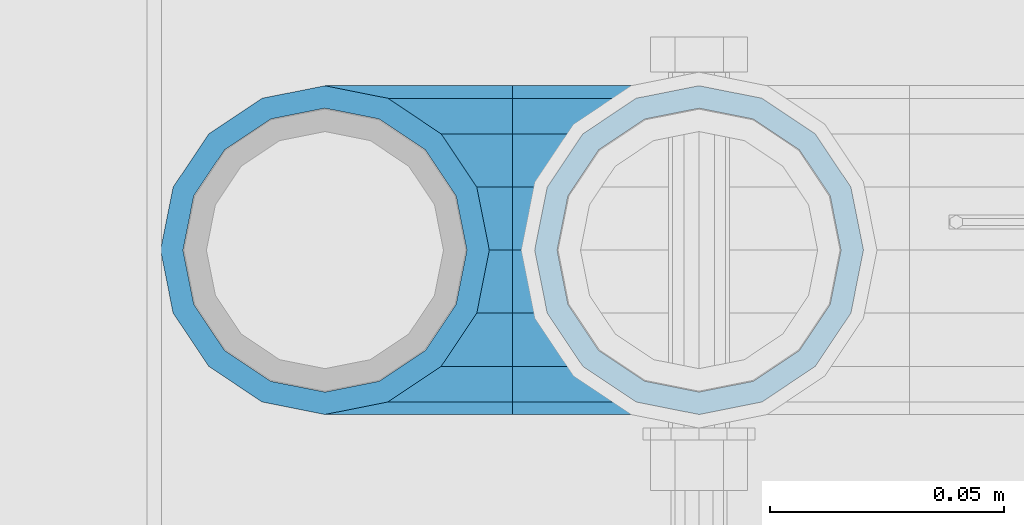
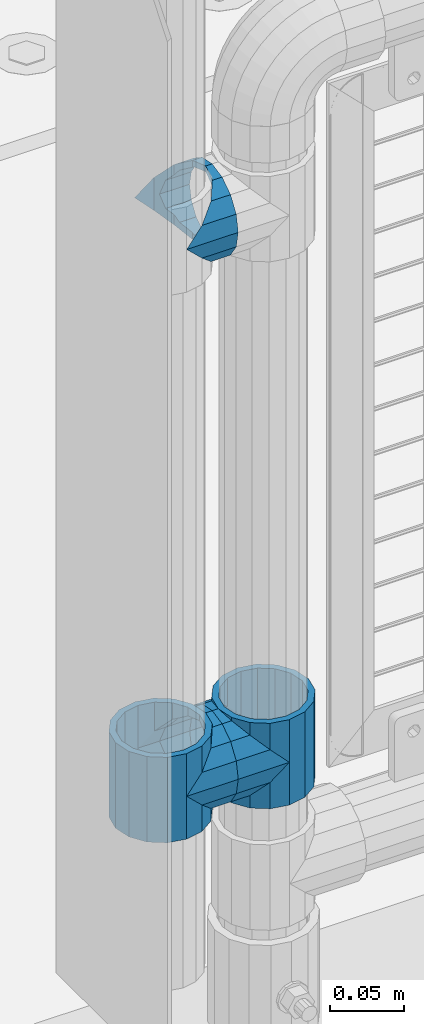
# One storey, part 144 of 247: 5 beams.
"""IFC2X3 building model written with IfcOpenShell, lengths in millimetres."""

from ifc_helpers import new_model, si_unit, frame, origin_with_axes, place, context, subcontext, project, spatial, faceted_brep, material, type_object, element, save


model = new_model("IFC2X3")

# Units and contexts
model_context = context("Model", 3, precision=1e-05, world=origin_with_axes())
body_context = subcontext(model_context, "Body", "Model", "MODEL_VIEW")
ifc_project = project(units=[si_unit("LENGTHUNIT", "METRE", prefix="MILLI"), si_unit("AREAUNIT", "SQUARE_METRE"), si_unit("VOLUMEUNIT", "CUBIC_METRE"), si_unit("MASSUNIT", "GRAM", prefix="KILO"), si_unit("TIMEUNIT", "SECOND"), si_unit("PLANEANGLEUNIT", "RADIAN"), si_unit("SOLIDANGLEUNIT", "STERADIAN"), si_unit("THERMODYNAMICTEMPERATUREUNIT", "DEGREE_CELSIUS"), si_unit("LUMINOUSINTENSITYUNIT", "LUMEN")], contexts=[model_context])

# Site, building, storey
site_placement = place(None, origin_with_axes())
site = spatial("IfcSite", under=ifc_project, at=site_placement, CompositionType="ELEMENT")
building_placement = place(site_placement, origin_with_axes())
building = spatial("IfcBuilding", under=site, at=building_placement, Name="Standard", CompositionType="ELEMENT")
storey_placement = place(building_placement, origin_with_axes())
storey = spatial("IfcBuildingStorey", under=building, at=storey_placement, Name="Undefined", CompositionType="ELEMENT", Elevation=0.0)

# Beams
ifc_material = material(Name="Misc_Undefined")
beam_type = type_object("IfcBeamType", PredefinedType="NOTDEFINED")
beam_1_placement = place(storey_placement, frame((541.0, 7664.5, 398.669999999999), z_axis=(0.0, -0.999999999999548, -9.5100000000016e-07), x_axis=(1.0, 0.0, 0.0)))
element("IfcBeam", 1, at=beam_1_placement, inside=storey, type_object=beam_type, material=ifc_material, context=body_context, shape_type="Brep", body=[
    faceted_brep([(0.0, 0.0, -35.1499999999996), (13.4513226476338, -13.4513226476329, -32.4743655677721), (13.4513226476338, 13.4513226476329, -32.4743655677721), (32.4743655677721, 32.4743655677717, 13.4513226476329), (32.4743655677721, 26.8123795176755, 13.4513226476329), (27.1226768591096, 21.4606908090117, 21.4606908090118), (24.8548033587067, 16.3810424080046, 24.8548033587067), (24.8548033587067, 24.8548033587072, 24.8548033587067), (0.0, 0.0, 35.1499999999996), (13.4513226476338, 13.4513226476329, 32.4743655677721), (13.4513226476338, -13.4513226476329, 32.4743655677721), (20.0882031229812, 11.6144421722805, 28.0397438117179), (16.6306603983649, 0.0, 30.3500000000004), (20.0882031229812, -11.6144421722805, 28.0397438117179), (24.8548033587067, -16.3810424080045, 24.8548033587067), (24.8548033587067, -24.8548033587072, 24.8548033587067), (27.1226768591096, -21.4606908090117, 21.4606908090118), (32.4743655677721, -26.8123795176755, 13.4513226476329), (32.4743655677721, -32.4743655677717, 13.4513226476329), (32.8397438117172, -28.0397438117175, 11.6144421722802), (35.1499999999996, -30.35, 0.0), (35.1499999999996, -35.15, 0.0), (32.4743655677721, -26.8123795176766, -13.4513226476329), (32.4743655677721, -32.4743655677717, -13.4513226476329), (32.8397438117172, -28.0397438117175, -11.6144421722802), (24.8548033587067, -16.3810424080045, -24.8548033587067), (24.8548033587067, -24.8548033587072, -24.8548033587067), (27.1226768591059, -21.4606908090117, -21.4606908090118), (20.0882031229885, -11.6144421722805, -28.0397438117179), (16.6306603983739, 0.0, -30.3500000000004), (20.0882031229885, 11.6144421722805, -28.0397438117179), (24.8548033587067, 16.3810424080029, -24.8548033587067), (24.8548033587067, 24.8548033587072, -24.8548033587067), (27.1226768591059, 21.4606908090117, -21.4606908090118), (32.4743655677721, 26.8123795176755, -13.4513226476329), (32.4743655677721, 32.4743655677717, -13.4513226476329), (32.8397438117172, 28.0397438117175, -11.6144421722802), (35.1499999999996, 30.35, 0.0), (35.1499999999996, 35.15, 0.0), (32.8397438117172, 28.0397438117175, 11.6144421722802), (40.1500000000015, -35.15, 0.0), (40.1500000000015, -32.4743655677717, 13.4513226476329), (40.1500000000015, -24.8548033587072, 24.8548033587067), (40.1500000000015, -13.4513226476329, 32.4743655677721), (40.1500000000015, 0.0, 35.1499999999996), (40.1500000000015, 13.4513226476329, 32.4743655677721), (40.1500000000015, 24.8548033587072, 24.8548033587067), (40.1500000000015, 32.4743655677717, 13.4513226476329), (40.1500000000015, 35.15, 0.0), (40.1500000000015, -24.8548033587072, -24.8548033587067), (40.1500000000015, -32.4743655677717, -13.4513226476329), (40.1500000000015, -13.4513226476329, -32.4743655677721), (40.1500000000015, 0.0, -35.1499999999996), (40.1500000000015, 13.4513226476329, -32.4743655677721), (40.1500000000015, 24.8548033587072, -24.8548033587067), (40.1500000000015, 32.4743655677717, -13.4513226476329), (40.1500000000015, -21.4606908090117, 21.4606908090118), (40.1500000000015, -11.6144421722805, 28.0397438117179), (40.1500000000015, 0.0, 30.3500000000004), (40.1500000000015, 11.6144421722805, 28.0397438117179), (40.1500000000015, 21.4606908090117, 21.4606908090118), (40.1500000000015, 28.0397438117175, 11.6144421722802), (40.1500000000015, 30.35, 0.0), (40.1500000000015, 28.0397438117175, -11.6144421722802), (40.1500000000015, 21.4606908090117, -21.4606908090118), (40.1500000000015, 11.6144421722805, -28.0397438117179), (40.1500000000015, 0.0, -30.3500000000004), (40.1500000000015, -11.6144421722805, -28.0397438117179), (40.1500000000015, -21.4606908090117, -21.4606908090118), (40.1500000000015, -28.0397438117175, -11.6144421722802), (40.1500000000015, -30.35, 0.0), (40.1500000000015, -28.0397438117175, 11.6144421722802)], [[[0, 1, 2]], [[3, 4, 5, 6, 7]], [[8, 9, 10]], [[7, 6, 11, 12, 13, 14, 15, 10, 9]], [[16, 17, 18, 15, 14]], [[19, 20, 21, 18, 17]], [[22, 23, 21, 20, 24]], [[25, 26, 23, 22, 27]], [[2, 1, 26, 25, 28, 29, 30, 31, 32]], [[32, 31, 33, 34, 35]], [[35, 34, 36, 37, 38]], [[38, 37, 39, 4, 3]], [[40, 41, 18, 21]], [[41, 42, 15, 18]], [[42, 43, 10, 15]], [[43, 44, 8, 10]], [[44, 45, 9, 8]], [[45, 46, 7, 9]], [[46, 47, 3, 7]], [[47, 48, 38, 3]], [[49, 50, 23, 26]], [[51, 49, 26, 1]], [[52, 51, 1, 0]], [[53, 52, 0, 2]], [[54, 53, 2, 32]], [[55, 54, 32, 35]], [[48, 55, 35, 38]], [[50, 40, 21, 23]], [[49, 51, 52, 53, 54, 55, 48, 47, 46, 45, 44, 43, 42, 41, 40, 50], [56, 57, 58, 59, 60, 61, 62, 63, 64, 65, 66, 67, 68, 69, 70, 71]], [[63, 62, 37, 36]], [[33, 64, 63, 36, 34]], [[30, 65, 64, 33, 31]], [[66, 65, 30, 29]], [[67, 66, 29, 28]], [[68, 67, 28, 25, 27]], [[69, 68, 27, 22, 24]], [[70, 69, 24, 20]], [[71, 70, 20, 19]], [[16, 56, 71, 19, 17]], [[13, 57, 56, 16, 14]], [[58, 57, 13, 12]], [[59, 58, 12, 11]], [[60, 59, 11, 6, 5]], [[61, 60, 5, 4, 39]], [[62, 61, 39, 37]]]),
])
beam_2_placement = place(storey_placement, frame((621.0, 7664.5, 398.669999999999), z_axis=(0.0, 1.0, 0.0), x_axis=(-1.0, 0.0, 0.0)))
element("IfcBeam", 2, at=beam_2_placement, inside=storey, type_object=beam_type, material=ifc_material, context=body_context, shape_type="Brep", body=[
    faceted_brep([(0.0, 0.0, -35.1499999999996), (13.4513226476338, -13.4513226476329, -32.4743655677721), (13.4513226476338, 13.4513226476329, -32.4743655677721), (27.1226768591096, -21.4606908090117, 21.4606908090118), (32.4743655677721, -26.8123795176755, 13.4513226476329), (32.4743655677721, -32.4743655677717, 13.4513226476329), (24.8548033587067, -24.8548033587072, 24.8548033587067), (24.8548033587067, -16.3810424080045, 24.8548033587067), (32.8397438117172, -28.0397438117175, 11.6144421722802), (35.1499999999996, -30.35, 0.0), (35.1499999999996, -35.15, 0.0), (32.4743655677721, -26.8123795176766, -13.4513226476329), (32.4743655677721, -32.4743655677717, -13.4513226476329), (32.8397438117172, -28.0397438117175, -11.6144421722802), (24.8548033587067, -16.3810424080045, -24.8548033587067), (24.8548033587067, -24.8548033587072, -24.8548033587067), (27.1226768591059, -21.4606908090117, -21.4606908090118), (20.0882031229885, -11.6144421722805, -28.0397438117179), (16.6306603983739, 0.0, -30.3500000000004), (20.0882031229885, 11.6144421722805, -28.0397438117179), (24.8548033587067, 16.3810424080029, -24.8548033587067), (24.8548033587067, 24.8548033587072, -24.8548033587067), (27.1226768591059, 21.4606908090117, -21.4606908090118), (32.4743655677721, 26.8123795176755, -13.4513226476329), (32.4743655677721, 32.4743655677717, -13.4513226476329), (32.8397438117172, 28.0397438117175, -11.6144421722802), (35.1499999999996, 30.35, 0.0), (35.1499999999996, 35.15, 0.0), (32.8397438117172, 28.0397438117175, 11.6144421722802), (32.4743655677721, 26.8123795176755, 13.4513226476329), (32.4743655677721, 32.4743655677717, 13.4513226476329), (27.1226768591096, 21.4606908090117, 21.4606908090118), (24.8548033587067, 16.3810424080046, 24.8548033587067), (24.8548033587067, 24.8548033587072, 24.8548033587067), (0.0, 0.0, 35.1499999999996), (13.4513226476338, 13.4513226476329, 32.4743655677721), (13.4513226476338, -13.4513226476329, 32.4743655677721), (20.0882031229812, 11.6144421722805, 28.0397438117179), (16.6306603983649, 0.0, 30.3500000000004), (20.0882031229812, -11.6144421722805, 28.0397438117179), (40.1500000000015, -35.15, 0.0), (40.1500000000015, -32.4743655677717, 13.4513226476329), (40.1500000000015, -24.8548033587072, 24.8548033587067), (40.1500000000015, -13.4513226476329, 32.4743655677721), (40.1500000000015, 0.0, 35.1499999999996), (40.1500000000015, -24.8548033587072, -24.8548033587067), (40.1500000000015, -32.4743655677717, -13.4513226476329), (40.1500000000015, -13.4513226476329, -32.4743655677721), (40.1500000000015, 0.0, -35.1499999999996), (40.1500000000015, 13.4513226476329, -32.4743655677721), (40.1500000000015, 24.8548033587072, -24.8548033587067), (40.1500000000015, 32.4743655677717, -13.4513226476329), (40.1500000000015, 35.15, 0.0), (40.1500000000015, 32.4743655677717, 13.4513226476329), (40.1500000000015, 24.8548033587072, 24.8548033587067), (40.1500000000015, 13.4513226476329, 32.4743655677721), (40.1500000000015, -21.4606908090117, 21.4606908090118), (40.1500000000015, -11.6144421722805, 28.0397438117179), (40.1500000000015, 0.0, 30.3500000000004), (40.1500000000015, 11.6144421722805, 28.0397438117179), (40.1500000000015, 21.4606908090117, 21.4606908090118), (40.1500000000015, 28.0397438117175, 11.6144421722802), (40.1500000000015, 30.35, 0.0), (40.1500000000015, 28.0397438117175, -11.6144421722802), (40.1500000000015, 21.4606908090117, -21.4606908090118), (40.1500000000015, 11.6144421722805, -28.0397438117179), (40.1500000000015, 0.0, -30.3500000000004), (40.1500000000015, -11.6144421722805, -28.0397438117179), (40.1500000000015, -21.4606908090117, -21.4606908090118), (40.1500000000015, -28.0397438117175, -11.6144421722802), (40.1500000000015, -30.35, 0.0), (40.1500000000015, -28.0397438117175, 11.6144421722802)], [[[0, 1, 2]], [[3, 4, 5, 6, 7]], [[8, 9, 10, 5, 4]], [[11, 12, 10, 9, 13]], [[14, 15, 12, 11, 16]], [[2, 1, 15, 14, 17, 18, 19, 20, 21]], [[21, 20, 22, 23, 24]], [[24, 23, 25, 26, 27]], [[27, 26, 28, 29, 30]], [[30, 29, 31, 32, 33]], [[34, 35, 36]], [[33, 32, 37, 38, 39, 7, 6, 36, 35]], [[40, 41, 5, 10]], [[41, 42, 6, 5]], [[42, 43, 36, 6]], [[43, 44, 34, 36]], [[45, 46, 12, 15]], [[47, 45, 15, 1]], [[48, 47, 1, 0]], [[49, 48, 0, 2]], [[50, 49, 2, 21]], [[51, 50, 21, 24]], [[52, 51, 24, 27]], [[53, 52, 27, 30]], [[54, 53, 30, 33]], [[55, 54, 33, 35]], [[44, 55, 35, 34]], [[46, 40, 10, 12]], [[45, 47, 48, 49, 50, 51, 52, 53, 54, 55, 44, 43, 42, 41, 40, 46], [56, 57, 58, 59, 60, 61, 62, 63, 64, 65, 66, 67, 68, 69, 70, 71]], [[59, 58, 38, 37]], [[60, 59, 37, 32, 31]], [[61, 60, 31, 29, 28]], [[62, 61, 28, 26]], [[63, 62, 26, 25]], [[22, 64, 63, 25, 23]], [[19, 65, 64, 22, 20]], [[66, 65, 19, 18]], [[67, 66, 18, 17]], [[68, 67, 17, 14, 16]], [[69, 68, 16, 11, 13]], [[70, 69, 13, 9]], [[71, 70, 9, 8]], [[3, 56, 71, 8, 4]], [[39, 57, 56, 3, 7]], [[58, 57, 39, 38]]]),
])
beam_3_placement = place(storey_placement, frame((541.0, 7664.5, 433.819999999999), z_axis=(-1.0, 0.0, 0.0), x_axis=(0.0, 0.0, -1.0)))
element("IfcBeam", 3, at=beam_3_placement, inside=storey, type_object=beam_type, material=ifc_material, context=body_context, shape_type="Brep", body=[
    faceted_brep([(13.6893091909879, -21.4606908090118, -21.4606908090118), (13.6893091909879, -21.4606908090118, -27.1226768591077), (8.33762048232325, -13.4513226476329, -32.4743655677721), (7.11025618828211, -11.6144421722802, -32.839743811719), (7.11025618828211, -11.6144421722802, -28.0397438117179), (23.5355578277191, -28.0397438117179, -11.6144421722802), (23.5355578277191, -28.0397438117179, -20.0882031229885), (18.768957591997, -24.8548033587067, -24.8548033587067), (35.1499999999996, -30.35, 0.0), (35.1499999999996, -30.3500000000004, -16.6306603983739), (46.7644421722801, -28.0397438117179, -11.6144421722802), (46.7644421722801, -28.0397438117179, -20.0882031229885), (56.6106908090114, -21.4606908090118, -21.4606908090118), (56.6106908090114, -21.4606908090118, -27.1226768591077), (51.5310424080038, -24.8548033587067, -24.8548033587067), (63.1897438117172, -11.6144421722802, -28.0397438117179), (63.1897438117172, -11.6144421722802, -32.839743811719), (61.9623795176754, -13.4513226476329, -32.4743655677721), (65.4999999999997, 0.0, -30.3500000000004), (65.4999999999997, 0.0, -35.1499999999996), (63.1897438117172, 11.6144421722802, -28.0397438117179), (63.1897438117172, 11.6144421722802, -32.839743811719), (56.6106908090114, 21.4606908090118, -21.4606908090118), (56.6106908090114, 21.4606908090118, -27.1226768591096), (61.9623795176755, 13.4513226476329, -32.4743655677721), (46.7644421722801, 28.0397438117179, -11.6144421722802), (46.7644421722801, 28.0397438117179, -20.088203122983), (51.5310424080055, 24.8548033587067, -24.8548033587067), (35.1499999999996, 30.35, 0.0), (35.1499999999996, 30.3500000000004, -16.6306603983649), (23.5355578277192, 28.0397438117179, -11.6144421722802), (23.5355578277192, 28.0397438117179, -20.088203122983), (13.6893091909879, 21.4606908090118, -21.4606908090118), (13.6893091909879, 21.4606908090118, -27.1226768591096), (18.768957591997, 24.8548033587067, -24.8548033587067), (7.11025618828211, 11.6144421722802, -28.0397438117179), (7.11025618828211, 11.6144421722802, -32.839743811719), (8.33762048232387, 13.4513226476329, -32.4743655677721), (4.79999999999961, 0.0, -30.3500000000004), (4.79999999999961, 0.0, -35.1499999999996), (0.0, 21.4606908090118, 21.4606908090118), (0.0, 28.0397438117179, 11.6144421722802), (70.2999999999993, 28.0397438117179, 11.6144421722802), (70.2999999999993, 21.4606908090118, 21.4606908090118), (0.0, 11.6144421722802, 28.0397438117179), (70.2999999999993, 11.6144421722802, 28.0397438117179), (0.0, 0.0, 30.3500000000004), (70.2999999999993, 0.0, 30.3500000000004), (0.0, -11.6144421722802, 28.0397438117179), (70.2999999999993, -11.6144421722802, 28.0397438117179), (0.0, -21.4606908090118, 21.4606908090118), (70.2999999999993, -21.4606908090118, 21.4606908090118), (0.0, -28.0397438117179, 11.6144421722802), (70.2999999999993, -28.0397438117179, 11.6144421722802), (0.0, -24.8548033587067, -24.8548033587067), (0.0, -13.4513226476329, -32.4743655677721), (0.0, 0.0, -35.1499999999996), (0.0, -32.4743655677721, 13.4513226476338), (0.0, -35.1499999999996, 0.0), (70.2999999999993, -35.1499999999996, 0.0), (70.2999999999993, -32.4743655677721, 13.4513226476338), (0.0, -24.8548033587067, 24.8548033587067), (70.2999999999993, -24.8548033587067, 24.8548033587067), (0.0, -13.4513226476329, 32.4743655677721), (70.2999999999993, -13.4513226476329, 32.4743655677721), (0.0, 0.0, 35.1499999999996), (70.2999999999993, 0.0, 35.1499999999996), (0.0, 13.4513226476329, 32.4743655677721), (70.2999999999993, 13.4513226476329, 32.4743655677721), (0.0, 24.8548033587067, 24.8548033587067), (70.2999999999993, 24.8548033587067, 24.8548033587067), (0.0, 32.4743655677721, 13.4513226476338), (70.2999999999993, 32.4743655677721, 13.4513226476338), (0.0, 35.1499999999996, 0.0), (70.2999999999993, 35.1499999999996, 0.0), (0.0, 32.4743655677721, -13.4513226476338), (70.2999999999993, 32.4743655677721, -13.4513226476338), (70.2999999999993, -13.4513226476329, -32.4743655677721), (70.2999999999993, -24.8548033587067, -24.8548033587067), (70.2999999999993, 0.0, -35.1499999999996), (70.2999999999993, 13.4513226476329, -32.4743655677721), (70.2999999999993, 24.8548033587067, -24.8548033587067), (0.0, 24.8548033587067, -24.8548033587067), (0.0, 13.4513226476329, -32.4743655677721), (70.2999999999993, -32.4743655677721, -13.4513226476338), (0.0, -32.4743655677721, -13.4513226476338), (0.0, -28.0397438117179, -11.6144421722802), (0.0, -21.4606908090118, -21.4606908090118), (0.0, -11.6144421722802, -28.0397438117179), (0.0, 0.0, -30.3500000000004), (0.0, 11.6144421722802, -28.0397438117179), (0.0, 21.4606908090118, -21.4606908090118), (0.0, 28.0397438117179, -11.6144421722802), (0.0, 30.3500000000004, 0.0), (0.0, -30.3500000000004, 0.0), (70.2999999999993, 30.3500000000004, 0.0), (70.2999999999993, 28.0397438117179, -11.6144421722802), (70.2999999999993, 21.4606908090118, -21.4606908090118), (70.2999999999993, 11.6144421722802, -28.0397438117179), (70.2999999999993, 0.0, -30.3500000000004), (70.2999999999993, -11.6144421722802, -28.0397438117179), (70.2999999999993, -21.4606908090118, -21.4606908090118), (70.2999999999993, -28.0397438117179, -11.6144421722802), (70.2999999999993, -30.3500000000004, 0.0)], [[[0, 1, 2, 3, 4]], [[5, 6, 7, 1, 0]], [[8, 9, 6, 5]], [[10, 11, 9, 8]], [[12, 13, 14, 11, 10]], [[15, 16, 17, 13, 12]], [[18, 19, 16, 15]], [[20, 21, 19, 18]], [[22, 23, 24, 21, 20]], [[25, 26, 27, 23, 22]], [[28, 29, 26, 25]], [[30, 31, 29, 28]], [[32, 33, 34, 31, 30]], [[35, 36, 37, 33, 32]], [[38, 39, 36, 35]], [[4, 3, 39, 38]], [[40, 41, 42, 43]], [[44, 40, 43, 45]], [[46, 44, 45, 47]], [[48, 46, 47, 49]], [[50, 48, 49, 51]], [[52, 50, 51, 53]], [[54, 55, 2, 1, 7]], [[55, 56, 39, 3, 2]], [[57, 58, 59, 60]], [[61, 57, 60, 62]], [[63, 61, 62, 64]], [[65, 63, 64, 66]], [[67, 65, 66, 68]], [[69, 67, 68, 70]], [[71, 69, 70, 72]], [[73, 71, 72, 74]], [[75, 73, 74, 76]], [[17, 77, 78, 14, 13]], [[19, 79, 77, 17, 16]], [[80, 79, 19, 21, 24]], [[81, 80, 24, 23, 27]], [[34, 82, 75, 76, 81, 27, 26, 29, 31]], [[37, 83, 82, 34, 33]], [[39, 56, 83, 37, 36]], [[14, 78, 84, 85, 54, 7, 6, 9, 11]], [[58, 85, 84, 59]], [[57, 61, 63, 65, 67, 69, 71, 73, 75, 82, 83, 56, 55, 54, 85, 58], [86, 87, 88, 89, 90, 91, 92, 93, 41, 40, 44, 46, 48, 50, 52, 94]], [[90, 89, 38, 35]], [[91, 90, 35, 32]], [[92, 91, 32, 30]], [[93, 92, 30, 28]], [[41, 93, 28, 95, 42]], [[96, 95, 28, 25]], [[97, 96, 25, 22]], [[98, 97, 22, 20]], [[99, 98, 20, 18]], [[100, 99, 18, 15]], [[101, 100, 15, 12]], [[102, 101, 12, 10]], [[103, 102, 10, 8]], [[78, 77, 79, 80, 81, 76, 74, 72, 70, 68, 66, 64, 62, 60, 59, 84], [51, 49, 47, 45, 43, 42, 95, 96, 97, 98, 99, 100, 101, 102, 103, 53]], [[8, 94, 52, 53, 103]], [[86, 94, 8, 5]], [[87, 86, 5, 0]], [[88, 87, 0, 4]], [[89, 88, 4, 38]]]),
])
beam_4_placement = place(storey_placement, frame((621.0, 7664.5, 433.819999999999), z_axis=(1.0, 0.0, 0.0), x_axis=(0.0, 0.0, -1.0)))
element("IfcBeam", 4, at=beam_4_placement, inside=storey, type_object=beam_type, material=ifc_material, context=body_context, shape_type="Brep", body=[
    faceted_brep([(46.7644421722801, 28.0397438117179, -11.6144421722802), (46.7644421722801, 28.0397438117179, -20.088203122983), (51.5310424080055, 24.8548033587067, -24.8548033587067), (56.6106908090114, 21.4606908090118, -27.1226768591096), (56.6106908090114, 21.4606908090118, -21.4606908090118), (61.9623795176755, 13.4513226476329, -32.4743655677721), (63.1897438117172, 11.6144421722802, -32.839743811719), (63.1897438117172, 11.6144421722802, -28.0397438117179), (65.4999999999997, 0.0, -35.1499999999996), (65.4999999999997, 0.0, -30.3500000000004), (63.1897438117172, -11.6144421722802, -32.839743811719), (63.1897438117172, -11.6144421722802, -28.0397438117179), (61.9623795176754, -13.4513226476329, -32.4743655677721), (56.6106908090114, -21.4606908090118, -27.1226768591077), (56.6106908090114, -21.4606908090118, -21.4606908090118), (51.5310424080038, -24.8548033587067, -24.8548033587067), (46.7644421722801, -28.0397438117179, -20.0882031229885), (46.7644421722801, -28.0397438117179, -11.6144421722802), (35.1499999999996, -30.3500000000004, -16.6306603983739), (35.1499999999996, -30.35, 0.0), (23.5355578277191, -28.0397438117179, -20.0882031229885), (23.5355578277191, -28.0397438117179, -11.6144421722802), (18.768957591997, -24.8548033587067, -24.8548033587067), (13.6893091909879, -21.4606908090118, -27.1226768591077), (13.6893091909879, -21.4606908090118, -21.4606908090118), (8.33762048232325, -13.4513226476329, -32.4743655677721), (7.11025618828211, -11.6144421722802, -32.839743811719), (7.11025618828211, -11.6144421722802, -28.0397438117179), (4.79999999999961, 0.0, -35.1499999999996), (4.79999999999961, 0.0, -30.3500000000004), (7.11025618828211, 11.6144421722802, -32.839743811719), (7.11025618828211, 11.6144421722802, -28.0397438117179), (8.33762048232387, 13.4513226476329, -32.4743655677721), (13.6893091909879, 21.4606908090118, -27.1226768591096), (13.6893091909879, 21.4606908090118, -21.4606908090118), (18.768957591997, 24.8548033587067, -24.8548033587067), (23.5355578277192, 28.0397438117179, -20.088203122983), (23.5355578277192, 28.0397438117179, -11.6144421722802), (35.1499999999996, 30.3500000000004, -16.6306603983649), (35.1499999999996, 30.35, 0.0), (0.0, 32.4743655677721, -13.4513226476338), (0.0, 35.1499999999996, 0.0), (70.2999999999993, 35.1499999999996, 0.0), (70.2999999999993, 32.4743655677721, -13.4513226476338), (0.0, 32.4743655677721, 13.4513226476338), (70.2999999999993, 32.4743655677721, 13.4513226476338), (0.0, 24.8548033587067, 24.8548033587067), (70.2999999999993, 24.8548033587067, 24.8548033587067), (0.0, 13.4513226476329, 32.4743655677721), (70.2999999999993, 13.4513226476329, 32.4743655677721), (0.0, 0.0, 35.1499999999996), (70.2999999999993, 0.0, 35.1499999999996), (0.0, -13.4513226476329, 32.4743655677721), (70.2999999999993, -13.4513226476329, 32.4743655677721), (0.0, -24.8548033587067, 24.8548033587067), (70.2999999999993, -24.8548033587067, 24.8548033587067), (0.0, -32.4743655677721, 13.4513226476338), (70.2999999999993, -32.4743655677721, 13.4513226476338), (0.0, -35.1499999999996, 0.0), (70.2999999999993, -35.1499999999996, 0.0), (70.2999999999993, -30.3500000000004, 0.0), (70.2999999999993, -28.0397438117179, -11.6144421722802), (70.2999999999993, -21.4606908090118, -21.4606908090118), (70.2999999999993, -11.6144421722802, -28.0397438117179), (70.2999999999993, 0.0, -30.3500000000004), (70.2999999999993, 11.6144421722802, -28.0397438117179), (70.2999999999993, 21.4606908090118, -21.4606908090118), (70.2999999999993, 28.0397438117179, -11.6144421722802), (0.0, -28.0397438117179, -11.6144421722802), (0.0, -30.3500000000004, 0.0), (0.0, -21.4606908090118, -21.4606908090118), (0.0, -11.6144421722802, -28.0397438117179), (0.0, 0.0, -30.3500000000004), (0.0, 11.6144421722802, -28.0397438117179), (0.0, 21.4606908090118, -21.4606908090118), (0.0, 28.0397438117179, -11.6144421722802), (0.0, 30.3500000000004, 0.0), (70.2999999999993, 30.3500000000004, 0.0), (0.0, 28.0397438117179, 11.6144421722802), (70.2999999999993, 28.0397438117179, 11.6144421722802), (0.0, 21.4606908090118, 21.4606908090118), (70.2999999999993, 21.4606908090118, 21.4606908090118), (0.0, 11.6144421722802, 28.0397438117179), (70.2999999999993, 11.6144421722802, 28.0397438117179), (0.0, 0.0, 30.3500000000004), (70.2999999999993, 0.0, 30.3500000000004), (0.0, -11.6144421722802, 28.0397438117179), (70.2999999999993, -11.6144421722802, 28.0397438117179), (0.0, -21.4606908090118, 21.4606908090118), (70.2999999999993, -21.4606908090118, 21.4606908090118), (0.0, -28.0397438117179, 11.6144421722802), (70.2999999999993, -28.0397438117179, 11.6144421722802), (70.2999999999993, -24.8548033587067, -24.8548033587067), (70.2999999999993, -13.4513226476329, -32.4743655677721), (70.2999999999993, 0.0, -35.1499999999996), (70.2999999999993, 13.4513226476329, -32.4743655677721), (70.2999999999993, 24.8548033587067, -24.8548033587067), (70.2999999999993, -32.4743655677721, -13.4513226476338), (0.0, -32.4743655677721, -13.4513226476338), (0.0, 24.8548033587067, -24.8548033587067), (0.0, 13.4513226476329, -32.4743655677721), (0.0, 0.0, -35.1499999999996), (0.0, -13.4513226476329, -32.4743655677721), (0.0, -24.8548033587067, -24.8548033587067)], [[[0, 1, 2, 3, 4]], [[4, 3, 5, 6, 7]], [[7, 6, 8, 9]], [[9, 8, 10, 11]], [[11, 10, 12, 13, 14]], [[14, 13, 15, 16, 17]], [[17, 16, 18, 19]], [[19, 18, 20, 21]], [[21, 20, 22, 23, 24]], [[24, 23, 25, 26, 27]], [[27, 26, 28, 29]], [[29, 28, 30, 31]], [[31, 30, 32, 33, 34]], [[34, 33, 35, 36, 37]], [[37, 36, 38, 39]], [[39, 38, 1, 0]], [[40, 41, 42, 43]], [[41, 44, 45, 42]], [[44, 46, 47, 45]], [[46, 48, 49, 47]], [[48, 50, 51, 49]], [[50, 52, 53, 51]], [[52, 54, 55, 53]], [[54, 56, 57, 55]], [[56, 58, 59, 57]], [[60, 61, 17, 19]], [[61, 62, 14, 17]], [[62, 63, 11, 14]], [[63, 64, 9, 11]], [[64, 65, 7, 9]], [[65, 66, 4, 7]], [[66, 67, 0, 4]], [[68, 69, 19, 21]], [[70, 68, 21, 24]], [[71, 70, 24, 27]], [[72, 71, 27, 29]], [[73, 72, 29, 31]], [[74, 73, 31, 34]], [[75, 74, 34, 37]], [[76, 75, 37, 39]], [[67, 77, 39, 0]], [[78, 76, 39, 77, 79]], [[80, 78, 79, 81]], [[82, 80, 81, 83]], [[84, 82, 83, 85]], [[86, 84, 85, 87]], [[88, 86, 87, 89]], [[90, 88, 89, 91]], [[19, 69, 90, 91, 60]], [[92, 93, 94, 95, 96, 43, 42, 45, 47, 49, 51, 53, 55, 57, 59, 97], [89, 87, 85, 83, 81, 79, 77, 67, 66, 65, 64, 63, 62, 61, 60, 91]], [[58, 98, 97, 59]], [[56, 54, 52, 50, 48, 46, 44, 41, 40, 99, 100, 101, 102, 103, 98, 58], [68, 70, 71, 72, 73, 74, 75, 76, 78, 80, 82, 84, 86, 88, 90, 69]], [[32, 100, 99, 35, 33]], [[28, 101, 100, 32, 30]], [[102, 101, 28, 26, 25]], [[103, 102, 25, 23, 22]], [[15, 92, 97, 98, 103, 22, 20, 18, 16]], [[12, 93, 92, 15, 13]], [[8, 94, 93, 12, 10]], [[95, 94, 8, 6, 5]], [[96, 95, 5, 3, 2]], [[35, 99, 40, 43, 96, 2, 1, 38, 36]]]),
])
beam_5_placement = place(storey_placement, frame((541.0, 7664.5, 848.67), z_axis=(0.0, -0.999999999999548, -9.5100000000016e-07), x_axis=(1.0, 0.0, 0.0)))
element("IfcBeam", 5, at=beam_5_placement, inside=storey, type_object=beam_type, material=ifc_material, context=body_context, shape_type="Brep", body=[
    faceted_brep([(0.0, 0.0, -35.1499999999996), (13.4513226476338, -13.4513226476329, -32.4743655677721), (13.4513226476338, 13.4513226476329, -32.4743655677721), (32.4743655677721, 32.4743655677717, 13.4513226476329), (32.4743655677721, 26.8123795176755, 13.4513226476329), (27.1226768591096, 21.4606908090117, 21.4606908090118), (24.8548033587067, 16.3810424080046, 24.8548033587067), (24.8548033587067, 24.8548033587072, 24.8548033587067), (0.0, 0.0, 35.1499999999996), (13.4513226476338, 13.4513226476329, 32.4743655677721), (13.4513226476338, -13.4513226476329, 32.4743655677721), (20.0882031229812, 11.6144421722805, 28.0397438117179), (16.6306603983649, 0.0, 30.3500000000004), (20.0882031229812, -11.6144421722805, 28.0397438117179), (24.8548033587067, -16.3810424080045, 24.8548033587067), (24.8548033587067, -24.8548033587072, 24.8548033587067), (27.1226768591096, -21.4606908090117, 21.4606908090118), (32.4743655677721, -26.8123795176755, 13.4513226476329), (32.4743655677721, -32.4743655677717, 13.4513226476329), (32.8397438117172, -28.0397438117175, 11.6144421722802), (35.1499999999996, -30.35, 0.0), (35.1499999999996, -35.15, 0.0), (32.4743655677721, -26.8123795176766, -13.4513226476329), (32.4743655677721, -32.4743655677717, -13.4513226476329), (32.8397438117172, -28.0397438117175, -11.6144421722802), (24.8548033587067, -16.3810424080045, -24.8548033587067), (24.8548033587067, -24.8548033587072, -24.8548033587067), (27.1226768591059, -21.4606908090117, -21.4606908090118), (20.0882031229885, -11.6144421722805, -28.0397438117179), (16.6306603983739, 0.0, -30.3500000000004), (20.0882031229885, 11.6144421722805, -28.0397438117179), (24.8548033587067, 16.3810424080029, -24.8548033587067), (24.8548033587067, 24.8548033587072, -24.8548033587067), (27.1226768591059, 21.4606908090117, -21.4606908090118), (32.4743655677721, 26.8123795176755, -13.4513226476329), (32.4743655677721, 32.4743655677717, -13.4513226476329), (32.8397438117172, 28.0397438117175, -11.6144421722802), (35.1499999999996, 30.35, 0.0), (35.1499999999996, 35.15, 0.0), (32.8397438117172, 28.0397438117175, 11.6144421722802), (40.1500000000015, -35.15, 0.0), (40.1500000000015, -32.4743655677717, 13.4513226476329), (40.1500000000015, -24.8548033587072, 24.8548033587067), (40.1500000000015, -13.4513226476329, 32.4743655677721), (40.1500000000015, 0.0, 35.1499999999996), (40.1500000000015, 13.4513226476329, 32.4743655677721), (40.1500000000015, 24.8548033587072, 24.8548033587067), (40.1500000000015, 32.4743655677717, 13.4513226476329), (40.1500000000015, 35.15, 0.0), (40.1500000000015, -24.8548033587072, -24.8548033587067), (40.1500000000015, -32.4743655677717, -13.4513226476329), (40.1500000000015, -13.4513226476329, -32.4743655677721), (40.1500000000015, 0.0, -35.1499999999996), (40.1500000000015, 13.4513226476329, -32.4743655677721), (40.1500000000015, 24.8548033587072, -24.8548033587067), (40.1500000000015, 32.4743655677717, -13.4513226476329), (40.1500000000015, -21.4606908090117, 21.4606908090118), (40.1500000000015, -11.6144421722805, 28.0397438117179), (40.1500000000015, 0.0, 30.3500000000004), (40.1500000000015, 11.6144421722805, 28.0397438117179), (40.1500000000015, 21.4606908090117, 21.4606908090118), (40.1500000000015, 28.0397438117175, 11.6144421722802), (40.1500000000015, 30.35, 0.0), (40.1500000000015, 28.0397438117175, -11.6144421722802), (40.1500000000015, 21.4606908090117, -21.4606908090118), (40.1500000000015, 11.6144421722805, -28.0397438117179), (40.1500000000015, 0.0, -30.3500000000004), (40.1500000000015, -11.6144421722805, -28.0397438117179), (40.1500000000015, -21.4606908090117, -21.4606908090118), (40.1500000000015, -28.0397438117175, -11.6144421722802), (40.1500000000015, -30.35, 0.0), (40.1500000000015, -28.0397438117175, 11.6144421722802)], [[[0, 1, 2]], [[3, 4, 5, 6, 7]], [[8, 9, 10]], [[7, 6, 11, 12, 13, 14, 15, 10, 9]], [[16, 17, 18, 15, 14]], [[19, 20, 21, 18, 17]], [[22, 23, 21, 20, 24]], [[25, 26, 23, 22, 27]], [[2, 1, 26, 25, 28, 29, 30, 31, 32]], [[32, 31, 33, 34, 35]], [[35, 34, 36, 37, 38]], [[38, 37, 39, 4, 3]], [[40, 41, 18, 21]], [[41, 42, 15, 18]], [[42, 43, 10, 15]], [[43, 44, 8, 10]], [[44, 45, 9, 8]], [[45, 46, 7, 9]], [[46, 47, 3, 7]], [[47, 48, 38, 3]], [[49, 50, 23, 26]], [[51, 49, 26, 1]], [[52, 51, 1, 0]], [[53, 52, 0, 2]], [[54, 53, 2, 32]], [[55, 54, 32, 35]], [[48, 55, 35, 38]], [[50, 40, 21, 23]], [[49, 51, 52, 53, 54, 55, 48, 47, 46, 45, 44, 43, 42, 41, 40, 50], [56, 57, 58, 59, 60, 61, 62, 63, 64, 65, 66, 67, 68, 69, 70, 71]], [[63, 62, 37, 36]], [[33, 64, 63, 36, 34]], [[30, 65, 64, 33, 31]], [[66, 65, 30, 29]], [[67, 66, 29, 28]], [[68, 67, 28, 25, 27]], [[69, 68, 27, 22, 24]], [[70, 69, 24, 20]], [[71, 70, 20, 19]], [[16, 56, 71, 19, 17]], [[13, 57, 56, 16, 14]], [[58, 57, 13, 12]], [[59, 58, 12, 11]], [[60, 59, 11, 6, 5]], [[61, 60, 5, 4, 39]], [[62, 61, 39, 37]]]),
])

save(model, "model.ifc")
